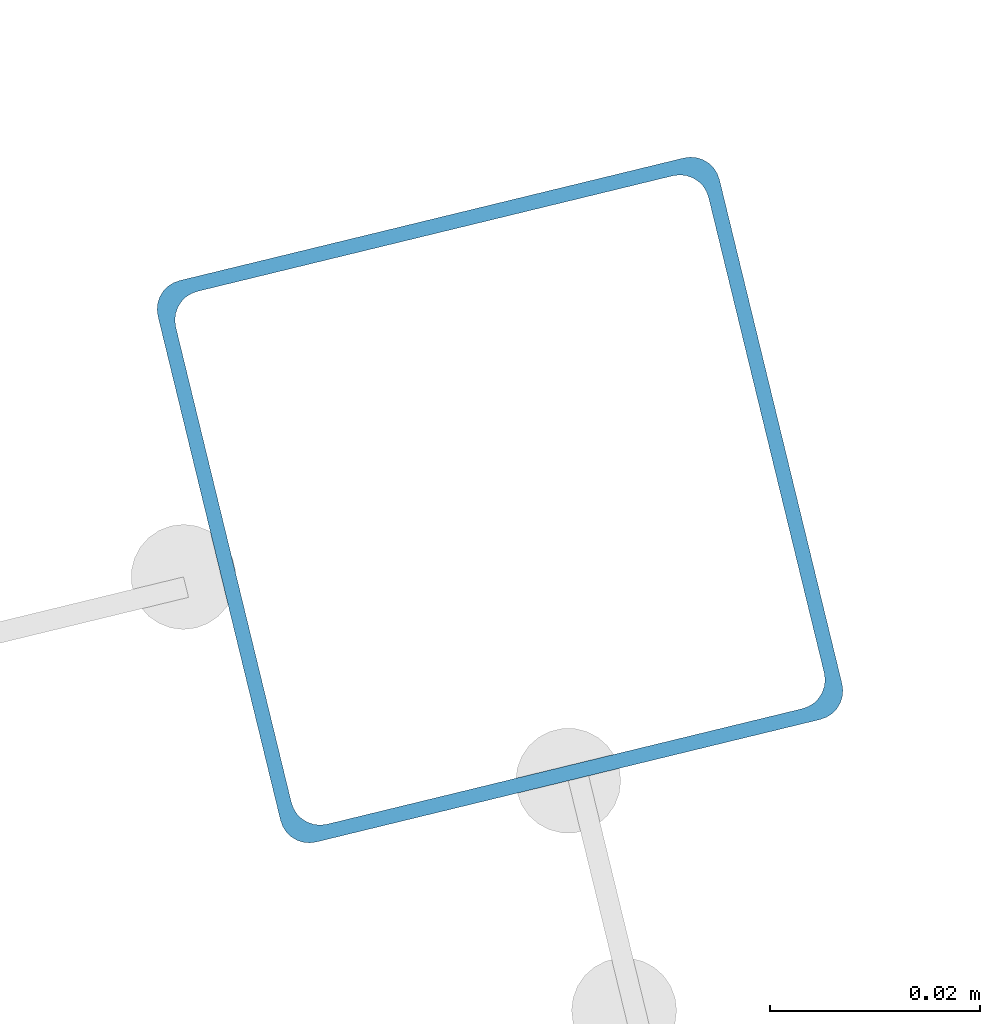
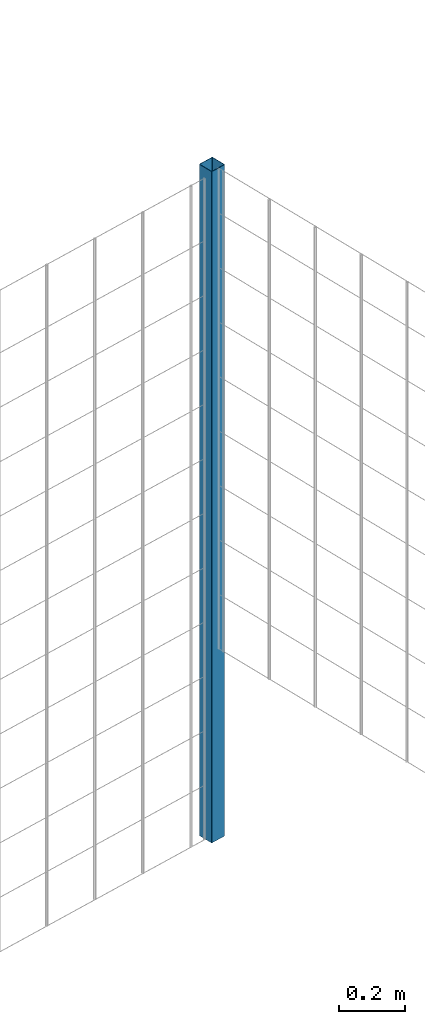
# One storey, part 5 of 10: 1 beam.
"""IFC2X3 building model written with IfcOpenShell, lengths in millimetres."""

from ifc_helpers import new_model, entity, si_unit, converted_unit, derived_unit, direction, frame, frame_2d, origin, place, context, subcontext, project, spatial, polyline, circle_curve, parameter, trimmed, segment, composite_curve, outline, extrude, material, type_object, element, save


model = new_model("IFC2X3")

# Units and contexts
model_context = context("Model", 3, precision=0.01, world=origin(), true_north=direction((6.12303176911189e-17, 1.0)))
body_context = subcontext(model_context, "Body", "Model", "MODEL_VIEW")
ifc_project = project(units=[si_unit("LENGTHUNIT", "METRE", prefix="MILLI"), si_unit("AREAUNIT", "SQUARE_METRE"), si_unit("VOLUMEUNIT", "CUBIC_METRE"), converted_unit("PLANEANGLEUNIT", "DEGREE", entity("IfcRatioMeasure", 0.0174532925199433), si_unit("PLANEANGLEUNIT", "RADIAN"), dimensions=[0, 0, 0, 0, 0, 0, 0]), si_unit("MASSUNIT", "GRAM", prefix="KILO"), derived_unit("MASSDENSITYUNIT", [(si_unit("MASSUNIT", "GRAM", prefix="KILO"), 1), (si_unit("LENGTHUNIT", "METRE"), -3)]), derived_unit("MOMENTOFINERTIAUNIT", [(si_unit("LENGTHUNIT", "METRE"), 4)]), si_unit("TIMEUNIT", "SECOND"), si_unit("FREQUENCYUNIT", "HERTZ"), si_unit("THERMODYNAMICTEMPERATUREUNIT", "DEGREE_CELSIUS"), derived_unit("THERMALTRANSMITTANCEUNIT", [(si_unit("MASSUNIT", "GRAM", prefix="KILO"), 1), (si_unit("THERMODYNAMICTEMPERATUREUNIT", "KELVIN"), -1), (si_unit("TIMEUNIT", "SECOND"), -3)]), derived_unit("VOLUMETRICFLOWRATEUNIT", [(si_unit("LENGTHUNIT", "METRE"), 3), (si_unit("TIMEUNIT", "SECOND"), -1)]), derived_unit("MASSFLOWRATEUNIT", [(si_unit("MASSUNIT", "GRAM", prefix="KILO"), 1), (si_unit("TIMEUNIT", "SECOND"), -1)]), derived_unit("ROTATIONALFREQUENCYUNIT", [(si_unit("TIMEUNIT", "SECOND"), -1)]), si_unit("ELECTRICCURRENTUNIT", "AMPERE"), si_unit("ELECTRICVOLTAGEUNIT", "VOLT"), si_unit("POWERUNIT", "WATT"), si_unit("FORCEUNIT", "NEWTON", prefix="KILO"), si_unit("ILLUMINANCEUNIT", "LUX"), si_unit("LUMINOUSFLUXUNIT", "LUMEN"), si_unit("LUMINOUSINTENSITYUNIT", "CANDELA"), derived_unit("USERDEFINED", [(si_unit("MASSUNIT", "GRAM", prefix="KILO"), -1), (si_unit("LENGTHUNIT", "METRE"), -2), (si_unit("TIMEUNIT", "SECOND"), 3), (si_unit("LUMINOUSFLUXUNIT", "LUMEN"), 1)]), derived_unit("LINEARVELOCITYUNIT", [(si_unit("LENGTHUNIT", "METRE"), 1), (si_unit("TIMEUNIT", "SECOND"), -1)]), si_unit("PRESSUREUNIT", "PASCAL"), derived_unit("USERDEFINED", [(si_unit("LENGTHUNIT", "METRE"), -2), (si_unit("MASSUNIT", "GRAM", prefix="KILO"), 1), (si_unit("TIMEUNIT", "SECOND"), -2)]), derived_unit("LINEARFORCEUNIT", [(si_unit("MASSUNIT", "GRAM", prefix="KILO"), 1), (si_unit("LENGTHUNIT", "METRE"), 1), (si_unit("TIMEUNIT", "SECOND"), -2), (si_unit("LENGTHUNIT", "METRE"), -1)]), derived_unit("PLANARFORCEUNIT", [(si_unit("MASSUNIT", "GRAM", prefix="KILO"), 1), (si_unit("LENGTHUNIT", "METRE"), 1), (si_unit("TIMEUNIT", "SECOND"), -2), (si_unit("LENGTHUNIT", "METRE"), -2)])], contexts=[model_context])

# Site, building, storey
site_placement = place(None, frame((19171.746869958, -72498.5768491146, 0.0), z_axis=(0.0, 0.0, 1.0), x_axis=(0.971695960795463, 0.236234967296933, 0.0)))
site = spatial("IfcSite", under=ifc_project, at=site_placement, CompositionType="ELEMENT")
building_placement = place(site_placement, origin())
building = spatial("IfcBuilding", under=site, at=building_placement, CompositionType="ELEMENT")
storey_placement = place(building_placement, origin())
storey = spatial("IfcBuildingStorey", under=building, at=storey_placement, CompositionType="ELEMENT", Elevation=0.0)

# Beam
ifc_material = material()
beam_type = type_object("IfcBeamType", PredefinedType="NOTDEFINED")
beam_placement = place(storey_placement, frame((9845.9047277641, 5570.90472776409, 0.0), z_axis=(1.0, 0.0, 0.0), x_axis=(0.0, 0.0, -1.0)))
element("IfcBeam", 1, at=beam_placement, inside=storey, type_object=beam_type, material=ifc_material, context=body_context, shape_type="SweptSolid", body=[
    extrude(outline(composite_curve([segment(trimmed(circle_curve(frame_2d((24.6999999999987, -24.7000000000009), x_axis=(1.0, 0.0)), 2.79999999999974), [parameter(269.999999999999)], [parameter(1.32311074748882e-12)], True, "PARAMETER"), True, "CONTINUOUS"), segment(polyline([(27.499999999998, -24.700000000001), (27.4999999999971, 24.6999999999986)]), True, "CONTINUOUS"), segment(trimmed(circle_curve(frame_2d((24.6999999999988, 24.6999999999987), x_axis=(1.0, 0.0)), 2.79999999999845), [parameter(1.32311074748882e-12)], [parameter(90.0000000000001)], True, "PARAMETER"), True, "CONTINUOUS"), segment(polyline([(24.6999999999988, 27.499999999998), (-24.7000000000008, 27.4999999999981)]), True, "CONTINUOUS"), segment(trimmed(circle_curve(frame_2d((-24.7000000000008, 24.6999999999988), x_axis=(1.0, 0.0)), 2.79999999999845), [parameter(90.0000000000001)], [parameter(180.0)], True, "PARAMETER"), True, "CONTINUOUS"), segment(polyline([(-27.4999999999991, 24.6999999999988), (-27.4999999999992, -24.7000000000008)]), True, "CONTINUOUS"), segment(trimmed(circle_curve(frame_2d((-24.7000000000009, -24.7000000000008), x_axis=(1.0, 0.0)), 2.79999999999845), [parameter(180.0)], [parameter(269.999999999998)], True, "PARAMETER"), True, "CONTINUOUS"), segment(polyline([(-24.7000000000009, -27.499999999998), (24.6999999999986, -27.5000000000003)]), True, "CONTINUOUS")], self_intersect=False), holes=[composite_curve([segment(polyline([(23.299999999999, -26.1000000000006), (-23.3000000000013, -26.1000000000005)]), True, "CONTINUOUS"), segment(trimmed(circle_curve(frame_2d((-23.3000000000013, -23.3000000000011), x_axis=(1.0, 0.0)), 2.79999999999973), [parameter(180.0)], [parameter(270.0)], True, "PARAMETER"), False, "CONTINUOUS"), segment(polyline([(-26.1000000000017, -23.3000000000011), (-26.1000000000016, 23.2999999999991)]), True, "CONTINUOUS"), segment(trimmed(circle_curve(frame_2d((-23.3000000000011, 23.2999999999991), x_axis=(1.0, 0.0)), 2.79999999999973), [parameter(90.0000000000004)], [parameter(180.0)], True, "PARAMETER"), False, "CONTINUOUS"), segment(polyline([(-23.3000000000011, 26.0999999999984), (23.299999999998, 26.0999999999983)]), True, "CONTINUOUS"), segment(trimmed(circle_curve(frame_2d((23.299999999998, 23.299999999999), x_axis=(1.0, 0.0)), 2.79999999999973), [parameter(3.56222124323914e-13)], [parameter(90.0000000000004)], True, "PARAMETER"), False, "CONTINUOUS"), segment(polyline([(26.0999999999985, 23.299999999999), (26.0999999999983, -23.3000000000013)]), True, "CONTINUOUS"), segment(trimmed(circle_curve(frame_2d((23.2999999999979, -23.3000000000013), x_axis=(1.0, 0.0)), 2.80000000000034), [parameter(270.0)], [parameter(4.57999874130747e-13)], True, "PARAMETER"), False, "CONTINUOUS")], self_intersect=False)]), frame((-2465.97922445826, 29.0952722359151, 29.0952722359166), z_axis=(1.0, 0.0, 0.0), x_axis=(0.0, 1.0, 0.0)), (0.0, 0.0, 1.0), 2465.97922445826),
])

save(model, "model.ifc")
